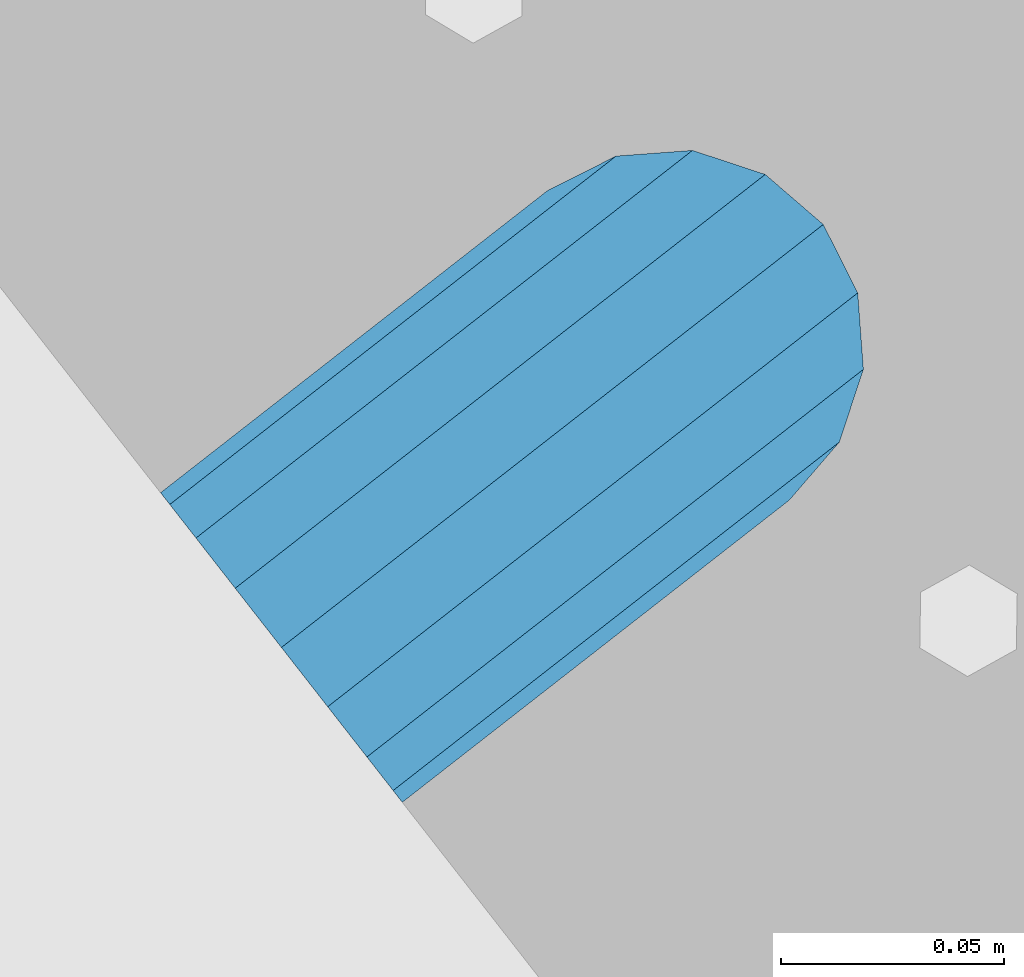
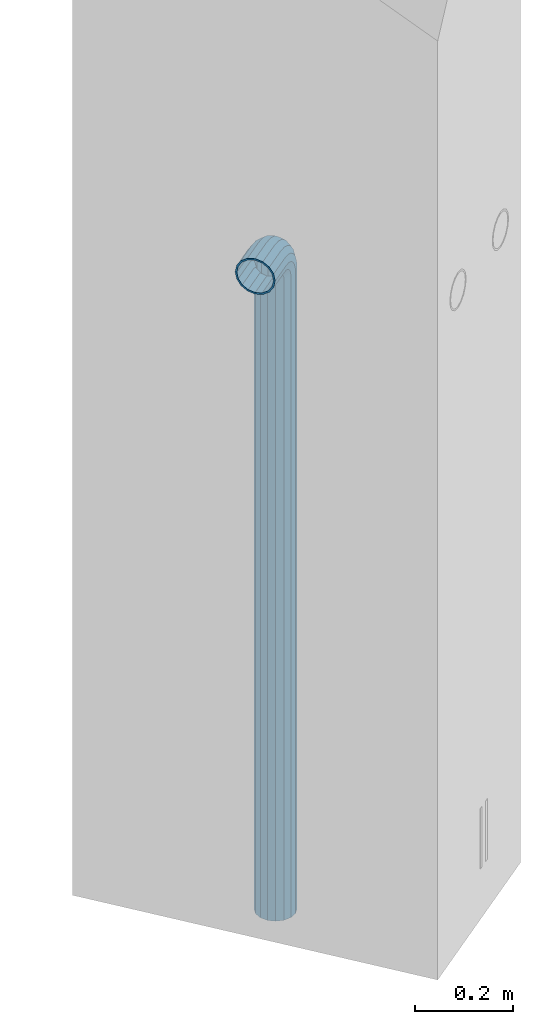
# One storey, part 7 of 42: 1 beam, 2 elements without a shape of their own.
"""IFC2X3 building model written with IfcOpenShell, lengths in millimetres."""

from ifc_helpers import new_model, si_unit, frame, origin_with_axes, place, context, subcontext, project, spatial, faceted_brep, material, type_object, element, aggregate, save


model = new_model("IFC2X3")

# Units and contexts
model_context = context("Model", 3, precision=1e-05, world=origin_with_axes())
body_context = subcontext(model_context, "Body", "Model", "MODEL_VIEW")
ifc_project = project(units=[si_unit("LENGTHUNIT", "METRE", prefix="MILLI"), si_unit("AREAUNIT", "SQUARE_METRE"), si_unit("VOLUMEUNIT", "CUBIC_METRE"), si_unit("MASSUNIT", "GRAM", prefix="KILO"), si_unit("TIMEUNIT", "SECOND"), si_unit("PLANEANGLEUNIT", "RADIAN"), si_unit("SOLIDANGLEUNIT", "STERADIAN"), si_unit("THERMODYNAMICTEMPERATUREUNIT", "DEGREE_CELSIUS"), si_unit("LUMINOUSINTENSITYUNIT", "LUMEN")], contexts=[model_context])

# Site, building, storey
site_placement = place(None, frame((171687.4, 84828.52, 14700.0), z_axis=(0.0, 0.0, 1.0), x_axis=(1.0, 0.0, 0.0)))
site = spatial("IfcSite", under=ifc_project, at=site_placement, CompositionType="ELEMENT")
building_placement = place(site_placement, origin_with_axes())
building = spatial("IfcBuilding", under=site, at=building_placement, Name="Undefined", CompositionType="ELEMENT")
storey_placement = place(building_placement, origin_with_axes())
storey = spatial("IfcBuildingStorey", under=building, at=storey_placement, Name="Undefined", CompositionType="ELEMENT", Elevation=0.0)

# Assemblies, beam
assembly_1_placement = place(storey_placement, origin_with_axes())
assembly_1 = element("IfcElementAssembly", 1, at=assembly_1_placement, inside=storey, AssemblyPlace="NOTDEFINED", PredefinedType="REINFORCEMENT_UNIT")
assembly_2_placement = place(assembly_1_placement, origin_with_axes())
assembly_2 = element("IfcElementAssembly", 2, at=assembly_2_placement, AssemblyPlace="NOTDEFINED", PredefinedType="RIGID_FRAME")
aggregate(assembly_1, [assembly_2])
ifc_material = material(Name="STEEL/NEG_BETON")
beam_type = type_object("IfcBeamType", PredefinedType="NOTDEFINED")
beam_placement = place(assembly_2_placement, frame((18006.1397254913, 265278.518974686, -1290.0), z_axis=(0.615386370178831, -0.788225611990706, 0.0), x_axis=(0.0, 0.0, 1.0)))
beam = element("IfcBeam", 3, at=beam_placement, type_object=beam_type, material=ifc_material, context=body_context, shape_type="Brep", body=[
    faceted_brep([(0.0, -43.999999753345, 2.88331648334861e-07), (0.0, -40.6506991838105, -16.8380707357428), (1590.0, -40.6506991838105, -16.8380707357428), (1589.99999999999, -43.999999753345, 2.88331648334861e-07), (0.0, -31.1126981254783, -31.1126980838017), (1590.0, -31.1126981254783, -31.1126980838017), (0.0, -16.8380707773322, -40.6506991419883), (1590.0, -16.8380707773322, -40.6506991419883), (0.0, 2.46742274612188e-07, -43.9999997114064), (1590.0, 2.46742274612188e-07, -43.9999997114064), (0.0, 16.8380712707876, -40.6506991418137), (1590.0, 16.8380712707876, -40.6506991418137), (0.0, 31.1126986189047, -31.1126980834524), (1590.0, 31.1126986189047, -31.1126980834524), (0.0, 40.6506996771204, -16.8380707352771), (1590.0, 40.6506996771204, -16.8380707352771), (0.0, 44.0000002465677, 2.88768205791712e-07), (1590.0, 44.0000002465677, 2.88768205791712e-07), (0.0, 40.6506996770622, 16.8380713128427), (1590.0, 40.6506996770622, 16.8380713128427), (0.0, 31.1126986187301, 31.1126986609306), (1590.0, 31.1126986187301, 31.1126986609306), (0.0, 16.8380712705839, 40.6506997191464), (1590.0, 16.8380712705839, 40.6506997191464), (0.0, 2.46509443968534e-07, 44.0000002885354), (1590.0, 2.46509443968534e-07, 44.0000002885354), (0.0, -16.8380707775359, 40.6506997189426), (1590.0, -16.8380707775359, 40.6506997189426), (0.0, -31.1126981256821, 31.1126986605814), (1590.0, -31.1126981256821, 31.1126986605814), (0.0, -40.6506991838978, 16.838071312377), (1590.0, -40.6506991838978, 16.838071312377), (4.47878846898675e-07, -40.0000000634464, 0.0), (4.47878846898675e-07, -36.9551813638827, 15.3073372946019), (1590.0, -36.9551810538396, 15.3073375829845), (1589.99999999999, -39.999999753345, 2.88360752165318e-07), (4.47937054559588e-07, -28.2842713108694, 28.284271247463), (1590.0, -28.2842710008845, 28.2842715359002), (4.4800981413573e-07, -15.3073373580119, 36.9551813004509), (1590.0, -15.3073370480561, 36.9551815889135), (4.48068021796644e-07, -6.34463503956795e-08, 40.0), (1590.0, 2.46538547798991e-07, 40.0000002885645), (4.48140781372786e-07, 15.3073372311774, 36.9551813004509), (1590.0, 15.3073375411332, 36.9551815890882), (4.48213540948927e-07, 28.2842711840058, 28.284271247463), (1590.0, 28.2842714939907, 28.2842715361621), (4.48271748609841e-07, 36.95518123699, 15.3073372946019), (1590.0, 36.9551815469749, 15.3073375833046), (4.48286300525069e-07, 39.9999999365536, 0.0), (1590.0, 40.0000002465677, 2.88768205791712e-07), (4.48271748609841e-07, 36.95518123699, -15.3073372946019), (1590.0, 36.9551815470913, -15.3073370058555), (4.48213540948927e-07, 28.2842711840058, -28.284271247463), (1590.0, 28.2842714941071, -28.2842709587712), (4.48140781372786e-07, 15.3073372311774, -36.9551813004509), (1590.0, 15.3073375413369, -36.9551810117846), (4.48068021796644e-07, -6.34463503956795e-08, -40.0), (1590.0, 2.46742274612188e-07, -39.9999997114064), (4.4800981413573e-07, -15.3073373580119, -36.9551813004509), (1590.0, -15.3073370479106, -36.9551810119592), (4.47937054559588e-07, -28.2842713108694, -28.284271247463), (1590.0, -28.284271000739, -28.2842709590332), (4.47878846898675e-07, -36.9551813638827, -15.3073372946019), (1590.0, -36.9551810537523, -15.3073370062048), (1614.32899023962, -40.7970274245017, 2.88331648334861e-07), (1613.46212746446, -37.5618515044625, 16.8380713124643), (1610.99351113837, -28.3488499511732, 31.1126986606105), (1607.29896571893, -14.5606187349476, 40.6506997189717), (1602.94095225511, 1.70370893206564, 44.0000002885354), (1598.5829387913, 17.9680365990498, 40.6506997191173), (1594.88839337186, 31.7562678153045, 31.1126986609015), (1592.41977704576, 40.9692693687393, 16.8380713128427), (1591.55291427061, 44.2044452888367, 2.88768205791712e-07), (1592.41977704576, 40.9692693687975, -16.8380707352771), (1594.88839337186, 31.7562678154791, -31.1126980834815), (1598.5829387913, 17.9680365993117, -40.6506991418428), (1602.94095225511, 1.70370893226936, -43.9999997114355), (1607.29896571893, -14.5606187347439, -40.6506991419592), (1610.99351113837, -28.3488499509695, -31.1126980837726), (1613.46212746446, -37.5618515043752, -16.8380707356846), (1613.29371405921, -36.9333241193672, 2.88360752165318e-07), (1612.50565699088, -33.9922551010677, -15.3073370062048), (1610.2614603308, -25.6167991434049, -28.2842709590041), (1606.90278267676, -13.0820434923226, -36.9551810119301), (1602.94095225511, 1.70370893226936, -39.9999997114355), (1598.97912183346, 16.4894613568322, -36.9551810117846), (1595.62044417943, 29.0242170079437, -28.284270958713), (1593.37624751934, 37.3996729654609, -15.3073370058846), (1592.58819045101, 40.3407419836731, 2.88739101961255e-07), (1593.37624751934, 37.3996729654027, 15.3073375833337), (1595.62044417943, 29.024217007769, 28.2842715361621), (1598.97912183346, 16.4894613566285, 36.9551815890882), (1602.94095225511, 1.70370893203653, 40.0000002885354), (1606.90278267676, -13.0820434924681, 36.9551815889135), (1610.2614603308, -25.6167991435796, 28.2842715358711), (1612.50565699088, -33.992255101155, 15.3073375829554), (1630.55634918609, -20.2456571130897, -31.1126980837435), (1635.32534971524, -28.5058083309559, -16.8380707356555), (1623.41903551202, -7.88346720003756, -40.6506991419301), (1614.99999999999, 6.69873005751288, -43.9999997113773), (1606.58096448796, 21.2809273150342, -40.6506991418137), (1599.44365081389, 33.6431172280572, -31.1126980834815), (1594.67465028474, 41.903268445807, -16.8380707352771), (1592.99999999999, 44.8038478238741, 2.88768205791712e-07), (1594.67465028474, 41.9032684457197, 16.8380713128427), (1599.44365081389, 33.6431172279117, 31.1126986609306), (1606.58096448796, 21.2809273148305, 40.6506997191173), (1614.99999999999, 6.69873005730915, 44.0000002885936), (1623.41903551202, -7.88346720024128, 40.6506997190008), (1630.55634918609, -20.2456571132934, 31.1126986606687), (1635.32534971524, -28.5058083310141, 16.8380713124934), (1636.99999999999, -31.4063877090521, 2.88418959826231e-07), (1633.47759065022, -25.3053957502707, 15.3073375830427), (1634.99999999999, -27.9422860939521, 2.88389855995774e-07), (1629.14213562372, -17.7961673704849, 28.2842715359293), (1622.65366864729, -6.55781290409504, 36.9551815889718), (1614.99999999999, 6.69873005730915, 40.0000002886227), (1607.34633135269, 19.9552730187133, 36.9551815891173), (1600.85786437626, 31.1936274851323, 28.2842715361621), (1596.52240934976, 38.7028558649763, 15.3073375833628), (1594.99999999999, 41.3397462087451, 2.88797309622169e-07), (1596.52240934976, 38.7028558650345, -15.3073370058555), (1600.85786437626, 31.1936274852778, -28.284270958713), (1607.34633135269, 19.9552730189171, -36.9551810117846), (1614.99999999999, 6.69873005751288, -39.9999997113482), (1622.65366864729, -6.55781290392042, -36.9551810119301), (1629.14213562372, -17.7961673703394, -28.284270958975), (1633.47759065022, -25.3053957501834, -15.3073370061757), (1647.35533905931, -7.35533881263109, -31.1126980836852), (1654.09972428659, -14.099724039901, -16.8380707355391), (1637.26165326253, 2.73834698420251, -40.6506991419301), (1625.35533905931, 14.644661187398, -43.9999997113482), (1613.4490248561, 26.5509753906226, -40.6506991417555), (1603.35533905931, 36.6446611873689, -31.1126980834233), (1596.61095383203, 43.3890464145807, -16.8380707352771), (1594.24264068711, 45.7573595594731, 2.88768205791712e-07), (1596.61095383203, 43.3890464145225, 16.8380713128427), (1603.35533905931, 36.6446611871943, 31.1126986609597), (1613.4490248561, 26.5509753903898, 40.6506997191755), (1625.35533905931, 14.6446611871943, 44.0000002886227), (1637.26165326252, 2.73834698399878, 40.6506997190299), (1647.35533905931, -7.3553388127475, 31.112698660756), (1654.09972428659, -14.0997240400175, 16.8380713125516), (1656.46803743151, -16.4680371848808, 2.88506271317601e-07), (1651.48659835683, -11.4865981102339, 15.3073375831009), (1653.63961030677, -13.6396100601123, 2.88535375148058e-07), (1645.35533905931, -5.3553388127475, 28.2842715359875), (1636.17926106223, 3.82073918430251, 36.9551815890009), (1625.35533905931, 14.6446611871652, 40.0000002885936), (1614.53141705639, 25.4685831901152, 36.9551815891173), (1605.35533905931, 34.6446611872234, 28.2842715362203), (1599.22407976179, 40.7759204847389, 15.3073375833919), (1597.07106781185, 42.9289324347337, 2.88797309622169e-07), (1599.22407976179, 40.7759204847971, -15.3073370058264), (1605.35533905931, 34.6446611873398, -28.284270958713), (1614.53141705639, 25.4685831902898, -36.9551810117264), (1625.35533905931, 14.644661187398, -39.9999997113773), (1636.17926106223, 3.82073918444803, -36.9551810118428), (1645.35533905931, -5.35533881263109, -28.2842709589459), (1651.48659835683, -11.4865981101757, -15.3073370061175), (1660.24565735981, 9.44365106063196, -31.1126980835688), (1668.50580857761, 4.67465053146589, -16.8380707354518), (1647.88346744677, 16.5809647346905, -40.6506991418428), (1633.3012701892, 25.0000002467132, -43.9999997113191), (1618.71907293164, 33.4190357587358, -40.6506991417555), (1606.35688301859, 40.5563494327944, -31.1126980834233), (1598.09673180079, 45.3253499618731, -16.838070735248), (1595.19615242269, 47.0000002465677, 2.88797309622169e-07), (1598.09673180079, 45.3253499617858, 16.8380713128718), (1606.35688301859, 40.5563494326198, 31.1126986609888), (1618.71907293164, 33.419035758503, 40.6506997192046), (1633.3012701892, 25.0000002465094, 44.0000002886809), (1647.88346744677, 16.5809647344868, 40.6506997191173), (1660.24565735981, 9.44365106045734, 31.1126986608433), (1668.50580857761, 4.67465053134947, 16.8380713126389), (1671.40638795571, 3.00000024662586, 2.88593582808971e-07), (1665.30539599685, 6.52240959636401, 15.3073375831882), (1667.94228634057, 5.00000024665496, 2.88622686639428e-07), (1657.79616761703, 10.8578646228416, 28.2842715360748), (1646.55781315062, 17.3463315992267, 36.9551815890882), (1633.3012701892, 25.0000002465094, 40.0000002886809), (1620.04472722778, 32.6536688937922, 36.9551815891464), (1608.80637276137, 39.1421358702646, 28.2842715361912), (1601.29714438156, 43.4775908967713, 15.3073375833628), (1598.66025403783, 45.0000002466259, 2.88797309622169e-07), (1601.29714438156, 43.4775908968586, -15.3073370057973), (1608.80637276137, 39.1421358704101, -28.2842709586548), (1620.04472722778, 32.6536688939959, -36.9551810117264), (1633.3012701892, 25.0000002467132, -39.99999971129), (1646.55781315062, 17.3463315994013, -36.9551810117846), (1657.79616761703, 10.857864622958, -28.2842709588294), (1665.30539599685, 6.52240959645133, -15.307337006001), (1668.34885019768, 29.0064891083166, -31.1126980834524), (1677.56185175105, 26.5378727821808, -16.8380707353354), (1654.56061898146, 32.7010345277959, -40.6506991417555), (1638.29629131443, 37.0590479915554, -43.9999997112609), (1622.0319636474, 41.4170614553732, -40.6506991417264), (1608.24373243118, 45.1116068747942, -31.1126980834233), (1599.03073087781, 47.5802232008427, -16.8380707352771), (1595.79555495772, 48.4470859759604, 2.88797309622169e-07), (1599.03073087781, 47.5802232007554, 16.8380713128427), (1608.24373243118, 45.1116068746196, 31.1126986609597), (1622.0319636474, 41.4170614551695, 40.6506997192628), (1638.29629131443, 37.0590479913517, 44.0000002887391), (1654.56061898146, 32.7010345275921, 40.6506997192337), (1668.34885019768, 29.0064891081711, 31.1126986609306), (1677.56185175105, 26.5378727821226, 16.8380713127845), (1680.79702767114, 25.671010007005, 2.88709998130798e-07), (1673.99225534772, 27.4943432556756, 15.3073375832755), (1676.93332436598, 26.7062861874001, 2.88680894300342e-07), (1665.61679939011, 29.7385399157356, 28.2842715361621), (1653.082043739, 33.0972175697389, 36.9551815891755), (1638.29629131443, 37.0590479913517, 40.00000028871), (1623.51053888986, 41.0208784130227, 36.9551815891755), (1610.97578323875, 44.3795560670551, 28.2842715362203), (1602.60032728114, 46.6237527272024, 15.3073375833919), (1599.65925826287, 47.4118097955652, 2.88826413452625e-07), (1602.60032728114, 46.6237527272606, -15.3073370057682), (1610.97578323875, 44.3795560672297, -28.2842709586548), (1623.51053888986, 41.0208784131974, -36.9551810116682), (1638.29629131443, 37.0590479915554, -39.9999997112609), (1653.082043739, 33.0972175699426, -36.9551810116682), (1665.61679939011, 29.7385399158811, -28.284270958713), (1673.99225534772, 27.4943432557629, -15.3073370058846), (1671.11269837217, 50.0000002466841, -31.1126980833651), (1680.65069943045, 50.0000002466259, -16.838070735248), (1656.83807102403, 50.0000002467132, -40.6506991416682), (1639.99999999997, 50.0000002466841, -43.9999997111736), (1623.16192897591, 50.0000002467132, -40.6506991416682), (1608.88730162777, 50.0000002466259, -31.1126980833942), (1599.34930056949, 50.0000002465968, -16.838070735248), (1595.99999999998, 50.0000002465677, 2.88826413452625e-07), (1599.34930056949, 50.0000002465677, 16.8380713129009), (1608.88730162777, 50.0000002465094, 31.1126986610179), (1623.16192897591, 50.0000002464803, 40.6506997192919), (1639.99999999997, 50.0000002464803, 44.0000002887973), (1656.83807102403, 50.0000002464803, 40.6506997192919), (1671.11269837217, 50.0000002465094, 31.1126986610179), (1680.65069943045, 50.0000002465677, 16.8380713128718), (1684.0, 50.0000002465677, 2.88826413452625e-07), (1676.95518130041, 50.0000002465385, 15.307337583421), (1680.0, 50.0000002465677, 2.88826413452625e-07), (1668.28427124742, 50.0000002465094, 28.2842715362785), (1655.30733729457, 50.0000002465094, 36.9551815892919), (1639.99999999997, 50.0000002464803, 40.0000002887973), (1624.69266270537, 50.0000002465094, 36.9551815892919), (1611.71572875252, 50.0000002465094, 28.2842715362785), (1603.04481869953, 50.0000002465385, 15.307337583421), (1599.99999999998, 50.0000002465677, 2.88826413452625e-07), (1603.04481869953, 50.0000002466259, -15.3073370057682), (1611.71572875252, 50.000000246655, -28.2842709586257), (1624.69266270537, 50.0000002466841, -36.95518101161), (1639.99999999997, 50.0000002466841, -39.9999997111736), (1655.30733729457, 50.0000002466841, -36.95518101161), (1668.28427124742, 50.000000246655, -28.2842709586257), (1676.95518130041, 50.0000002466259, -15.3073370057682), (1680.6506994305, 110.000000246597, -16.838070734957), (1684.0, 110.000000246539, 2.89117451757193e-07), (1671.11269837221, 110.000000246626, -31.1126980830741), (1656.83807102406, 110.000000246655, -40.650699141348), (1640.0, 110.000000246655, -43.9999997108534), (1623.16192897594, 110.000000246655, -40.650699141348), (1608.88730162779, 110.000000246626, -31.1126980830741), (1599.3493005695, 110.000000246597, -16.838070734957), (1596.0, 110.000000246539, 2.89117451757193e-07), (1599.3493005695, 110.000000246509, 16.8380713131919), (1608.88730162779, 110.00000024648, 31.1126986613381), (1623.16192897594, 110.000000246451, 40.6506997195829), (1640.0, 110.000000246422, 44.0000002891175), (1656.83807102406, 110.000000246451, 40.6506997195829), (1671.11269837221, 110.00000024648, 31.1126986613381), (1680.6506994305, 110.000000246509, 16.8380713131919), (1676.95518130045, 110.000000246509, 15.3073375837121), (1680.0, 110.000000246539, 2.89117451757193e-07), (1668.28427124746, 110.000000246451, 28.2842715365696), (1655.3073372946, 110.000000246422, 36.9551815895538), (1640.0, 110.000000246451, 40.0000002891175), (1624.6926627054, 110.000000246422, 36.9551815895538), (1611.71572875254, 110.000000246451, 28.2842715365696), (1603.04481869955, 110.000000246509, 15.3073375837121), (1600.0, 110.000000246539, 2.89117451757193e-07), (1603.04481869955, 110.000000246597, -15.3073370054772), (1611.71572875254, 110.000000246626, -28.2842709583347), (1624.6926627054, 110.000000246626, -36.955181011348), (1640.0, 110.000000246655, -39.9999997108534), (1655.3073372946, 110.000000246626, -36.955181011348), (1668.28427124746, 110.000000246626, -28.2842709583347), (1676.95518130045, 110.000000246597, -15.3073370054772)], [[[0, 1, 2, 3]], [[1, 4, 5, 2]], [[4, 6, 7, 5]], [[6, 8, 9, 7]], [[8, 10, 11, 9]], [[10, 12, 13, 11]], [[12, 14, 15, 13]], [[14, 16, 17, 15]], [[16, 18, 19, 17]], [[18, 20, 21, 19]], [[20, 22, 23, 21]], [[22, 24, 25, 23]], [[24, 26, 27, 25]], [[26, 28, 29, 27]], [[28, 30, 31, 29]], [[30, 0, 3, 31]], [[32, 33, 34, 35]], [[33, 36, 37, 34]], [[36, 38, 39, 37]], [[38, 40, 41, 39]], [[40, 42, 43, 41]], [[42, 44, 45, 43]], [[44, 46, 47, 45]], [[46, 48, 49, 47]], [[48, 50, 51, 49]], [[50, 52, 53, 51]], [[52, 54, 55, 53]], [[54, 56, 57, 55]], [[56, 58, 59, 57]], [[58, 60, 61, 59]], [[60, 62, 63, 61]], [[62, 32, 35, 63]], [[30, 28, 26, 24, 22, 20, 18, 16, 14, 12, 10, 8, 6, 4, 1, 0], [62, 60, 58, 56, 54, 52, 50, 48, 46, 44, 42, 40, 38, 36, 33, 32]], [[31, 3, 64, 65]], [[29, 31, 65, 66]], [[27, 29, 66, 67]], [[25, 27, 67, 68]], [[23, 25, 68, 69]], [[21, 23, 69, 70]], [[19, 21, 70, 71]], [[17, 19, 71, 72]], [[15, 17, 72, 73]], [[13, 15, 73, 74]], [[11, 13, 74, 75]], [[9, 11, 75, 76]], [[7, 9, 76, 77]], [[5, 7, 77, 78]], [[2, 5, 78, 79]], [[3, 2, 79, 64]], [[63, 35, 80, 81]], [[61, 63, 81, 82]], [[59, 61, 82, 83]], [[57, 59, 83, 84]], [[55, 57, 84, 85]], [[53, 55, 85, 86]], [[51, 53, 86, 87]], [[49, 51, 87, 88]], [[47, 49, 88, 89]], [[45, 47, 89, 90]], [[43, 45, 90, 91]], [[41, 43, 91, 92]], [[39, 41, 92, 93]], [[37, 39, 93, 94]], [[34, 37, 94, 95]], [[35, 34, 95, 80]], [[78, 96, 97, 79]], [[77, 98, 96, 78]], [[76, 99, 98, 77]], [[75, 100, 99, 76]], [[74, 101, 100, 75]], [[73, 102, 101, 74]], [[72, 103, 102, 73]], [[71, 104, 103, 72]], [[70, 105, 104, 71]], [[69, 106, 105, 70]], [[68, 107, 106, 69]], [[67, 108, 107, 68]], [[66, 109, 108, 67]], [[65, 110, 109, 66]], [[64, 111, 110, 65]], [[79, 97, 111, 64]], [[95, 112, 113, 80]], [[94, 114, 112, 95]], [[93, 115, 114, 94]], [[92, 116, 115, 93]], [[91, 117, 116, 92]], [[90, 118, 117, 91]], [[89, 119, 118, 90]], [[88, 120, 119, 89]], [[87, 121, 120, 88]], [[86, 122, 121, 87]], [[85, 123, 122, 86]], [[84, 124, 123, 85]], [[83, 125, 124, 84]], [[82, 126, 125, 83]], [[81, 127, 126, 82]], [[80, 113, 127, 81]], [[96, 128, 129, 97]], [[98, 130, 128, 96]], [[99, 131, 130, 98]], [[100, 132, 131, 99]], [[101, 133, 132, 100]], [[102, 134, 133, 101]], [[103, 135, 134, 102]], [[104, 136, 135, 103]], [[105, 137, 136, 104]], [[106, 138, 137, 105]], [[107, 139, 138, 106]], [[108, 140, 139, 107]], [[109, 141, 140, 108]], [[110, 142, 141, 109]], [[111, 143, 142, 110]], [[97, 129, 143, 111]], [[112, 144, 145, 113]], [[114, 146, 144, 112]], [[115, 147, 146, 114]], [[116, 148, 147, 115]], [[117, 149, 148, 116]], [[118, 150, 149, 117]], [[119, 151, 150, 118]], [[120, 152, 151, 119]], [[121, 153, 152, 120]], [[122, 154, 153, 121]], [[123, 155, 154, 122]], [[124, 156, 155, 123]], [[125, 157, 156, 124]], [[126, 158, 157, 125]], [[127, 159, 158, 126]], [[113, 145, 159, 127]], [[128, 160, 161, 129]], [[130, 162, 160, 128]], [[131, 163, 162, 130]], [[132, 164, 163, 131]], [[133, 165, 164, 132]], [[134, 166, 165, 133]], [[135, 167, 166, 134]], [[136, 168, 167, 135]], [[137, 169, 168, 136]], [[138, 170, 169, 137]], [[139, 171, 170, 138]], [[140, 172, 171, 139]], [[141, 173, 172, 140]], [[142, 174, 173, 141]], [[143, 175, 174, 142]], [[129, 161, 175, 143]], [[144, 176, 177, 145]], [[146, 178, 176, 144]], [[147, 179, 178, 146]], [[148, 180, 179, 147]], [[149, 181, 180, 148]], [[150, 182, 181, 149]], [[151, 183, 182, 150]], [[152, 184, 183, 151]], [[153, 185, 184, 152]], [[154, 186, 185, 153]], [[155, 187, 186, 154]], [[156, 188, 187, 155]], [[157, 189, 188, 156]], [[158, 190, 189, 157]], [[159, 191, 190, 158]], [[145, 177, 191, 159]], [[160, 192, 193, 161]], [[162, 194, 192, 160]], [[163, 195, 194, 162]], [[164, 196, 195, 163]], [[165, 197, 196, 164]], [[166, 198, 197, 165]], [[167, 199, 198, 166]], [[168, 200, 199, 167]], [[169, 201, 200, 168]], [[170, 202, 201, 169]], [[171, 203, 202, 170]], [[172, 204, 203, 171]], [[173, 205, 204, 172]], [[174, 206, 205, 173]], [[175, 207, 206, 174]], [[161, 193, 207, 175]], [[176, 208, 209, 177]], [[178, 210, 208, 176]], [[179, 211, 210, 178]], [[180, 212, 211, 179]], [[181, 213, 212, 180]], [[182, 214, 213, 181]], [[183, 215, 214, 182]], [[184, 216, 215, 183]], [[185, 217, 216, 184]], [[186, 218, 217, 185]], [[187, 219, 218, 186]], [[188, 220, 219, 187]], [[189, 221, 220, 188]], [[190, 222, 221, 189]], [[191, 223, 222, 190]], [[177, 209, 223, 191]], [[192, 224, 225, 193]], [[194, 226, 224, 192]], [[195, 227, 226, 194]], [[196, 228, 227, 195]], [[197, 229, 228, 196]], [[198, 230, 229, 197]], [[199, 231, 230, 198]], [[200, 232, 231, 199]], [[201, 233, 232, 200]], [[202, 234, 233, 201]], [[203, 235, 234, 202]], [[204, 236, 235, 203]], [[205, 237, 236, 204]], [[206, 238, 237, 205]], [[207, 239, 238, 206]], [[193, 225, 239, 207]], [[208, 240, 241, 209]], [[210, 242, 240, 208]], [[211, 243, 242, 210]], [[212, 244, 243, 211]], [[213, 245, 244, 212]], [[214, 246, 245, 213]], [[215, 247, 246, 214]], [[216, 248, 247, 215]], [[217, 249, 248, 216]], [[218, 250, 249, 217]], [[219, 251, 250, 218]], [[220, 252, 251, 219]], [[221, 253, 252, 220]], [[222, 254, 253, 221]], [[223, 255, 254, 222]], [[209, 241, 255, 223]], [[239, 225, 256, 257]], [[225, 224, 258, 256]], [[224, 226, 259, 258]], [[226, 227, 260, 259]], [[227, 228, 261, 260]], [[228, 229, 262, 261]], [[229, 230, 263, 262]], [[230, 231, 264, 263]], [[231, 232, 265, 264]], [[232, 233, 266, 265]], [[233, 234, 267, 266]], [[234, 235, 268, 267]], [[235, 236, 269, 268]], [[236, 237, 270, 269]], [[237, 238, 271, 270]], [[238, 239, 257, 271]], [[241, 240, 272, 273]], [[240, 242, 274, 272]], [[242, 243, 275, 274]], [[243, 244, 276, 275]], [[244, 245, 277, 276]], [[245, 246, 278, 277]], [[246, 247, 279, 278]], [[247, 248, 280, 279]], [[248, 249, 281, 280]], [[249, 250, 282, 281]], [[250, 251, 283, 282]], [[251, 252, 284, 283]], [[252, 253, 285, 284]], [[253, 254, 286, 285]], [[254, 255, 287, 286]], [[255, 241, 273, 287]], [[258, 259, 260, 261, 262, 263, 264, 265, 266, 267, 268, 269, 270, 271, 257, 256], [274, 275, 276, 277, 278, 279, 280, 281, 282, 283, 284, 285, 286, 287, 273, 272]]]),
])
aggregate(assembly_2, [beam])

save(model, "model.ifc")
